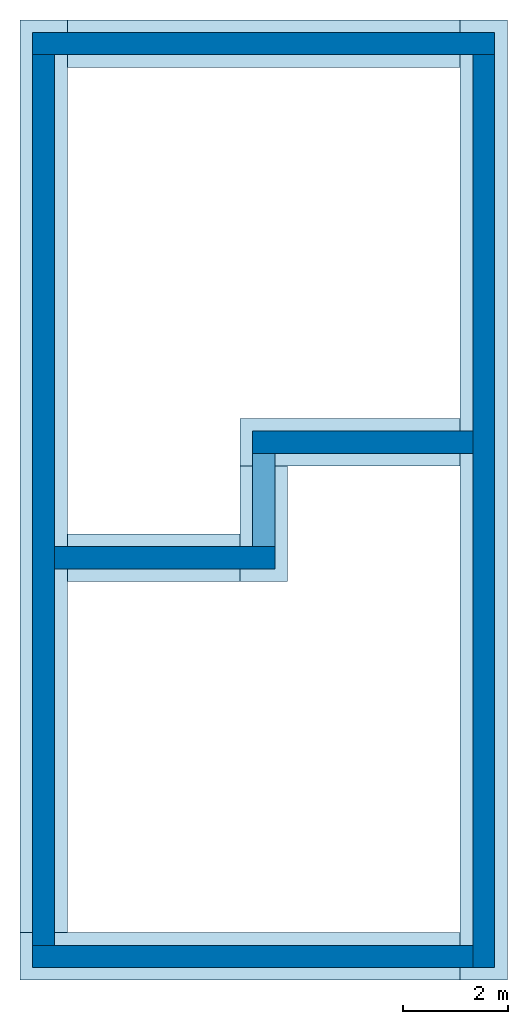
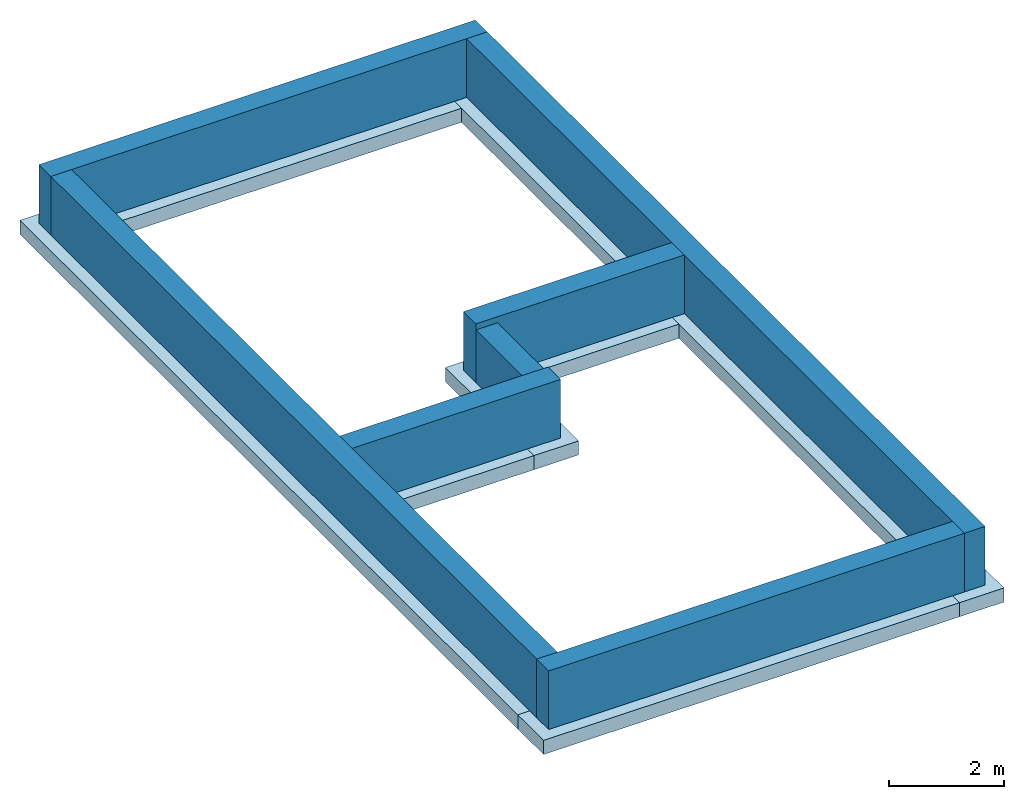
# One storey: 7 footings, 7 walls.
"""IFC2X3 building model written with IfcOpenShell, lengths in metres."""

from ifc_helpers import new_model, entity, si_unit, converted_unit, frame, frame_2d, origin, origin_2d_with_axis, place, context, project, spatial, rectangle, extrude, material, layer, layer_set, layer_usage, element, save


model = new_model("IFC2X3")

# Units and contexts
model_context = context("Model", 3, precision=1e-09, world=origin())
plan_context = context("Plan", 3, precision=1e-09, world=origin())
ifc_project = project(units=[si_unit("LENGTHUNIT", "METRE"), si_unit("AREAUNIT", "SQUARE_METRE"), si_unit("VOLUMEUNIT", "CUBIC_METRE"), converted_unit("PLANEANGLEUNIT", "DEGREE", entity("IfcRatioMeasure", 0.0174532925199433), si_unit("PLANEANGLEUNIT", "RADIAN"), dimensions=[0, 0, 0, 0, 0, 0, 0]), si_unit("TIMEUNIT", "SECOND")], contexts=[model_context, plan_context])

# Site, building, storey
site_placement = place(None, origin())
site = spatial("IfcSite", under=ifc_project, at=site_placement, CompositionType="ELEMENT")
building_placement = place(site_placement, origin())
building = spatial("IfcBuilding", under=site, at=building_placement, CompositionType="ELEMENT")
storey_placement = place(building_placement, frame((0.0, 0.0, -1.25)))
storey = spatial("IfcBuildingStorey", under=building, at=storey_placement, Name="T/FDN", CompositionType="ELEMENT", Elevation=-1.25)

# Footings
footing_1_placement = place(storey_placement, origin())
element("IfcFooting", 1, at=footing_1_placement, inside=storey, Name="Wall Foundation:Bearing Footing - 900 x 300", ObjectType="Wall Foundation:Bearing Footing - 900 x 300", PredefinedType="STRIP_FOOTING", context=model_context, shape_type="SweptSolid", body=[
    extrude(rectangle(XDim=18.283, YDim=0.9, at=frame_2d((0.275000000000004, 0.225), x_axis=(1.0, 0.0))), frame((8.36649999999999, -8.62500000000001, -0.3), z_axis=(0.0, 0.0, 1.0), x_axis=(0.0, -1.0, 0.0)), (0.0, 0.0, 1.0), 0.3),
])
footing_2_placement = place(storey_placement, origin())
element("IfcFooting", 2, at=footing_2_placement, inside=storey, Name="Wall Foundation:Bearing Footing - 900 x 300", ObjectType="Wall Foundation:Bearing Footing - 900 x 300", PredefinedType="STRIP_FOOTING", context=model_context, shape_type="SweptSolid", body=[
    extrude(rectangle(XDim=8.38299999999997, YDim=0.900000000000001, at=frame_2d((0.658299999999997, -0.0899999999999981), x_axis=(1.0, 0.0))), frame((3.29169999999999, -17.5015, -0.3)), (0.0, 0.0, 1.0), 0.3),
])
footing_3_placement = place(storey_placement, origin())
element("IfcFooting", 3, at=footing_3_placement, inside=storey, Name="Wall Foundation:Bearing Footing - 900 x 300", ObjectType="Wall Foundation:Bearing Footing - 900 x 300", PredefinedType="STRIP_FOOTING", context=model_context, shape_type="SweptSolid", body=[
    extrude(rectangle(XDim=17.383, YDim=0.9, at=frame_2d((0.670214285714283, -0.192857142857143), x_axis=(1.0, 0.0))), frame((0.401357142857144, -7.77978571428571, -0.3), z_axis=(0.0, 0.0, 1.0), x_axis=(0.0, -1.0, 0.0)), (0.0, 0.0, 1.0), 0.3),
])
footing_4_placement = place(storey_placement, origin())
element("IfcFooting", 4, at=footing_4_placement, inside=storey, Name="Wall Foundation:Bearing Footing - 900 x 300", ObjectType="Wall Foundation:Bearing Footing - 900 x 300", PredefinedType="STRIP_FOOTING", context=model_context, shape_type="SweptSolid", body=[
    extrude(rectangle(XDim=7.483, YDim=0.9, at=origin_2d_with_axis()), frame((4.4, -0.208500000000012, -0.3), z_axis=(0.0, 0.0, 1.0), x_axis=(-1.0, 0.0, 0.0)), (0.0, 0.0, 1.0), 0.3),
])
footing_5_placement = place(storey_placement, origin())
element("IfcFooting", 5, at=footing_5_placement, inside=storey, Name="Wall Foundation:Bearing Footing - 900 x 300", ObjectType="Wall Foundation:Bearing Footing - 900 x 300", PredefinedType="STRIP_FOOTING", context=model_context, shape_type="SweptSolid", body=[
    extrude(rectangle(XDim=4.1915, YDim=0.9, at=frame_2d((-0.239149999999999, -0.0899999999999988), x_axis=(1.0, 0.0))), frame((5.80659999999999, -7.88999999999999, -0.3), z_axis=(0.0, 0.0, 1.0), x_axis=(-1.0, 0.0, 0.0)), (0.0, 0.0, 1.0), 0.3),
])
footing_6_placement = place(storey_placement, origin())
element("IfcFooting", 6, at=footing_6_placement, inside=storey, Name="Wall Foundation:Bearing Footing - 900 x 300", ObjectType="Wall Foundation:Bearing Footing - 900 x 300", PredefinedType="STRIP_FOOTING", context=model_context, shape_type="SweptSolid", body=[
    extrude(rectangle(XDim=2.20000000000003, YDim=0.9, at=frame_2d((0.0400000000000036, -0.0899999999999998), x_axis=(1.0, 0.0))), frame((4.31, -9.39000000000001, -0.3), z_axis=(0.0, 0.0, 1.0), x_axis=(0.0, 1.0, 0.0)), (0.0, 0.0, 1.0), 0.3),
])
footing_7_placement = place(storey_placement, origin())
element("IfcFooting", 7, at=footing_7_placement, inside=storey, Name="Wall Foundation:Bearing Footing - 900 x 300", ObjectType="Wall Foundation:Bearing Footing - 900 x 300", PredefinedType="STRIP_FOOTING", context=model_context, shape_type="SweptSolid", body=[
    extrude(rectangle(XDim=3.29149999999999, YDim=0.899999999999999, at=origin_2d_with_axis()), frame((2.30425, -10.0, -0.3)), (0.0, 0.0, 1.0), 0.3),
])

# Walls
ifc_material = material(Name="Concrete - Cast In Situ")
ifc_layer_1 = layer(ifc_material, 0.417)
ifc_layer_set_1 = layer_set([ifc_layer_1], Name="Basic Wall:Foundation - Concrete (417mm)")
ifc_layer_usage_1 = layer_usage(ifc_layer_set_1, "AXIS2", "NEGATIVE", 0.2085)
wall_1_placement = place(storey_placement, frame((0.0, -0.208499999999998, 0.0)))
element("IfcWallStandardCase", 8, at=wall_1_placement, inside=storey, material=ifc_layer_usage_1, Name="Basic Wall:Foundation - Concrete (417mm)", ObjectType="Basic Wall:Foundation - Concrete (417mm)", context=model_context, shape_type="SweptSolid", body=[
    extrude(rectangle(XDim=8.8, YDim=0.417, at=frame_2d((4.4, 0.0), x_axis=(-1.0, 0.0))), origin(), (0.0, 0.0, 1.0), 1.25),
])
ifc_layer_usage_2 = layer_usage(ifc_layer_set_1, "AXIS2", "NEGATIVE", 0.2085)
wall_2_placement = place(storey_placement, frame((8.5915, -0.417000000000026, 0.0), z_axis=(0.0, 0.0, 1.0), x_axis=(0.0, -1.0, 0.0)))
element("IfcWallStandardCase", 9, at=wall_2_placement, inside=storey, material=ifc_layer_usage_2, Name="Basic Wall:Foundation - Concrete (417mm)", ObjectType="Basic Wall:Foundation - Concrete (417mm)", context=model_context, shape_type="SweptSolid", body=[
    extrude(rectangle(XDim=17.383, YDim=0.417, at=frame_2d((8.69149999999999, 0.0), x_axis=(-1.0, 0.0))), origin(), (0.0, 0.0, 1.0), 1.25),
])
ifc_layer_usage_3 = layer_usage(ifc_layer_set_1, "AXIS2", "NEGATIVE", 0.2085)
wall_3_placement = place(storey_placement, frame((8.38299999999998, -17.5915, 0.0), z_axis=(0.0, 0.0, 1.0), x_axis=(-1.0, 0.0, 0.0)))
element("IfcWallStandardCase", 10, at=wall_3_placement, inside=storey, material=ifc_layer_usage_3, Name="Basic Wall:Foundation - Concrete (417mm)", ObjectType="Basic Wall:Foundation - Concrete (417mm)", context=model_context, shape_type="SweptSolid", body=[
    extrude(rectangle(XDim=8.38299999999998, YDim=0.417, at=frame_2d((4.19149999999999, 0.0), x_axis=(-1.0, 0.0))), origin(), (0.0, 0.0, 1.0), 1.25),
])
ifc_layer_usage_4 = layer_usage(ifc_layer_set_1, "AXIS2", "NEGATIVE", 0.2085)
wall_4_placement = place(storey_placement, frame((0.208500000000001, -17.383, 0.0), z_axis=(0.0, 0.0, 1.0), x_axis=(0.0, 1.0, 0.0)))
element("IfcWallStandardCase", 11, at=wall_4_placement, inside=storey, material=ifc_layer_usage_4, Name="Basic Wall:Foundation - Concrete (417mm)", ObjectType="Basic Wall:Foundation - Concrete (417mm)", context=model_context, shape_type="SweptSolid", body=[
    extrude(rectangle(XDim=16.966, YDim=0.417, at=frame_2d((8.48299999999999, 0.0), x_axis=(-1.0, 0.0))), origin(), (0.0, 0.0, 1.0), 1.25),
])
ifc_layer_2 = layer(ifc_material, 0.435)
ifc_layer_set_2 = layer_set([ifc_layer_2], Name="Basic Wall:Foundation - Concrete (435mm)")
ifc_layer_usage_5 = layer_usage(ifc_layer_set_2, "AXIS2", "NEGATIVE", 0.2175)
wall_5_placement = place(storey_placement, frame((8.38299999999999, -7.8, 0.0), z_axis=(0.0, 0.0, 1.0), x_axis=(-1.0, 0.0, 0.0)))
element("IfcWallStandardCase", 12, at=wall_5_placement, inside=storey, material=ifc_layer_usage_5, Name="Basic Wall:Foundation - Concrete (435mm)", ObjectType="Basic Wall:Foundation - Concrete (435mm)", context=model_context, shape_type="SweptSolid", body=[
    extrude(rectangle(XDim=4.2005, YDim=0.435000000000001, at=frame_2d((2.10025, 0.0), x_axis=(-1.0, 0.0))), origin(), (0.0, 0.0, 1.0), 1.25),
])
ifc_layer_usage_6 = layer_usage(ifc_layer_set_2, "AXIS2", "NEGATIVE", 0.2175)
wall_6_placement = place(storey_placement, frame((0.417, -10.0, 0.0)))
element("IfcWallStandardCase", 13, at=wall_6_placement, inside=storey, material=ifc_layer_usage_6, Name="Basic Wall:Foundation - Concrete (435mm)", ObjectType="Basic Wall:Foundation - Concrete (435mm)", context=model_context, shape_type="SweptSolid", body=[
    extrude(rectangle(XDim=4.20049999999999, YDim=0.435000000000001, at=frame_2d((2.10025, 0.0), x_axis=(-1.0, 0.0))), origin(), (0.0, 0.0, 1.0), 1.25),
])
ifc_layer_usage_7 = layer_usage(ifc_layer_set_2, "AXIS2", "NEGATIVE", 0.2175)
wall_7_placement = place(storey_placement, frame((4.39999999999999, -9.78250000000001, 0.0), z_axis=(0.0, 0.0, 1.0), x_axis=(0.0, 1.0, 0.0)))
element("IfcWallStandardCase", 14, at=wall_7_placement, inside=storey, material=ifc_layer_usage_7, Name="Basic Wall:Foundation - Concrete (435mm)", ObjectType="Basic Wall:Foundation - Concrete (435mm)", context=model_context, shape_type="SweptSolid", body=[
    extrude(rectangle(XDim=1.76500000000003, YDim=0.435, at=frame_2d((0.882500000000014, 0.0), x_axis=(-1.0, 0.0))), origin(), (0.0, 0.0, 1.0), 1.123),
])

save(model, "model.ifc")
